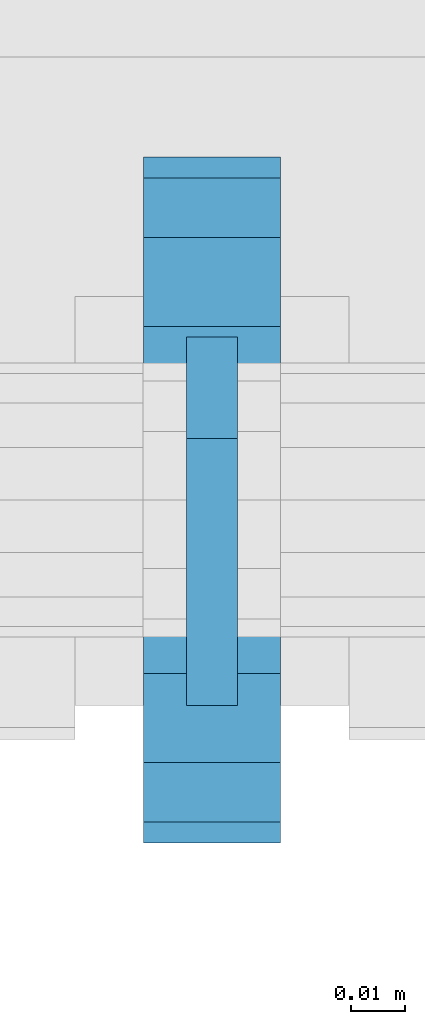
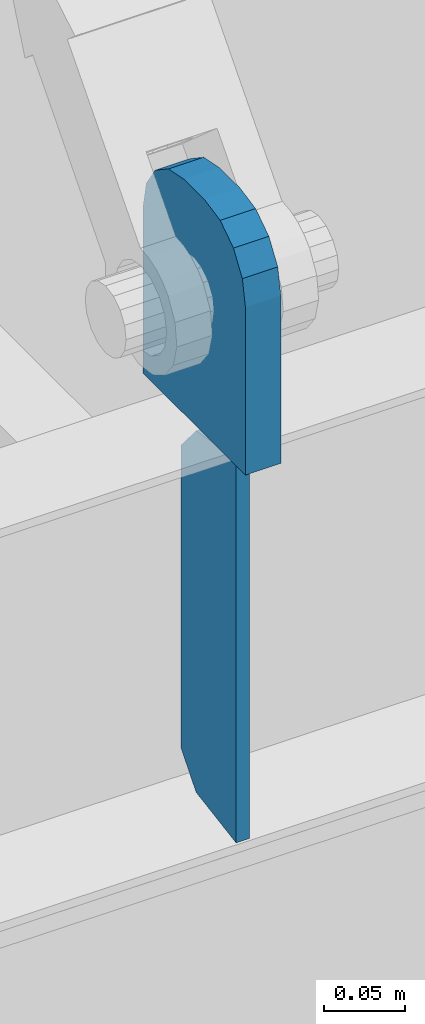
# One storey, part 1447 of 1763: 2 plates, 1 element without a shape of its own.
"""IFC2X3 building model written with IfcOpenShell, lengths in millimetres."""

from ifc_helpers import new_model, si_unit, frame, origin_with_axes, place, context, subcontext, project, spatial, faceted_brep, material, type_object, element, aggregate, save


model = new_model("IFC2X3")

# Units and contexts
model_context = context("Model", 3, precision=1e-05, world=origin_with_axes())
body_context = subcontext(model_context, "Body", "Model", "MODEL_VIEW")
ifc_project = project(units=[si_unit("LENGTHUNIT", "METRE", prefix="MILLI"), si_unit("AREAUNIT", "SQUARE_METRE"), si_unit("VOLUMEUNIT", "CUBIC_METRE"), si_unit("MASSUNIT", "GRAM", prefix="KILO"), si_unit("TIMEUNIT", "SECOND"), si_unit("PLANEANGLEUNIT", "RADIAN"), si_unit("SOLIDANGLEUNIT", "STERADIAN"), si_unit("THERMODYNAMICTEMPERATUREUNIT", "DEGREE_CELSIUS"), si_unit("LUMINOUSINTENSITYUNIT", "LUMEN")], contexts=[model_context])

# Site, building, storey
site_placement = place(None, origin_with_axes())
site = spatial("IfcSite", under=ifc_project, at=site_placement, CompositionType="ELEMENT")
building_placement = place(site_placement, origin_with_axes())
building = spatial("IfcBuilding", under=site, at=building_placement, Name="Undefined", CompositionType="ELEMENT")
storey_placement = place(building_placement, origin_with_axes())
storey = spatial("IfcBuildingStorey", under=building, at=storey_placement, Name="Undefined", CompositionType="ELEMENT", Elevation=0.0)

# Assembly, plates
assembly_placement = place(storey_placement, origin_with_axes())
assembly = element("IfcElementAssembly", 1, at=assembly_placement, inside=storey, Name="BEAM", AssemblyPlace="NOTDEFINED", PredefinedType="RIGID_FRAME")
ifc_material = material(Name="STEEL/A36")
plate_type_1 = type_object("IfcPlateType", PredefinedType="NOTDEFINED")
plate_1_placement = place(assembly_placement, frame((-58927.4270098568, -16681.452583842, 8440.7619207156), z_axis=(0.0, -0.164335003932505, 0.986404585594828), x_axis=(0.0, 0.986404585594827, 0.164335003932507)))
plate_1 = element("IfcPlate", 2, at=plate_1_placement, type_object=plate_type_1, material=ifc_material, Name="PLATE", context=body_context, shape_type="Brep", body=[
    faceted_brep([(0.0, -4.76249999999982, 0.0), (47.7369384761423, -4.76249999999709, 286.536254883109), (47.7369384761423, 4.76249999999709, 286.536254883109), (0.0, 4.76249999999982, 0.0), (95.1814043146169, -4.76249999999709, 270.276469957982), (95.1814043146169, 4.76249999999709, 270.276469957982), (110.071894935774, -4.76249999999709, 245.309426724465), (110.071894935774, 4.76249999999709, 245.309426724465), (72.333927817599, -4.76249999999709, 18.7910066254462), (72.333927817599, 4.76249999999709, 18.7910066254462), (50.1533470153317, -4.76249999999709, 3.09228198602796e-11), (50.1533470153317, 4.76249999999709, 3.09228198602796e-11)], [[[0, 1, 2, 3]], [[1, 4, 5, 2]], [[4, 6, 7, 5]], [[6, 8, 9, 7]], [[8, 10, 11, 9]], [[10, 0, 3, 11]], [[5, 7, 9, 11, 3, 2]], [[10, 8, 6, 4, 1, 0]]]),
])
plate_type_2 = type_object("IfcPlateType", PredefinedType="NOTDEFINED")
plate_2_placement = place(assembly_placement, frame((-58927.4270098567, -16706.8525869816, 8915.4), z_axis=(0.0, 1.0, 0.0), x_axis=(0.0, 0.0, -1.0)))
plate_2 = element("IfcPlate", 3, at=plate_2_placement, type_object=plate_type_2, material=ifc_material, Name="PLATE", context=body_context, shape_type="Brep", body=[
    faceted_brep([(0.0, -12.6999999999971, 50.7999992370605), (-5.45696821063757e-12, -12.7000000000098, 76.1999999999971), (5.45696821063757e-12, 12.7000000000116, 76.1999999999971), (0.0, 12.6999999999971, 50.7999992370605), (3.86691969035201, -12.6999999999971, 95.6403188351214), (3.86691969035201, 12.6999999999971, 95.6403188351214), (14.8789752922639, -12.6999999999971, 112.121024707736), (14.8789752922639, 12.6999999999971, 112.121024707736), (31.3596811648786, -12.6999999999971, 123.13308030965), (31.3596811648786, 12.6999999999971, 123.13308030965), (50.7999992370605, -12.6999999999971, 127.0), (50.7999992370605, 12.6999999999971, 127.0), (177.800003051758, -12.6999999999971, 127.0), (177.800003051758, 12.6999999999971, 127.0), (177.800003051758, -12.6999999999971, 0.0), (177.800003051758, 12.6999999999971, 0.0), (50.7999992370605, -12.6999999999971, 0.0), (50.7999992370605, 12.6999999999971, 0.0), (31.3596811648786, -12.6999999999971, 3.86691969035019), (31.3596811648786, 12.6999999999971, 3.86691969035019), (14.8789752922639, -12.6999999999971, 14.8789752922639), (14.8789752922639, 12.6999999999971, 14.8789752922639), (3.86691969035201, -12.6999999999971, 31.3596811648786), (3.86691969035201, 12.6999999999971, 31.3596811648786)], [[[0, 1, 2, 3]], [[1, 4, 5, 2]], [[4, 6, 7, 5]], [[6, 8, 9, 7]], [[8, 10, 11, 9]], [[10, 12, 13, 11]], [[12, 14, 15, 13]], [[14, 16, 17, 15]], [[16, 18, 19, 17]], [[18, 20, 21, 19]], [[20, 22, 23, 21]], [[22, 0, 3, 23]], [[5, 7, 9, 11, 13, 15, 17, 19, 21, 23, 3, 2]], [[22, 20, 18, 16, 14, 12, 10, 8, 6, 4, 1, 0]]]),
])
aggregate(assembly, [plate_1, plate_2])

save(model, "model.ifc")
